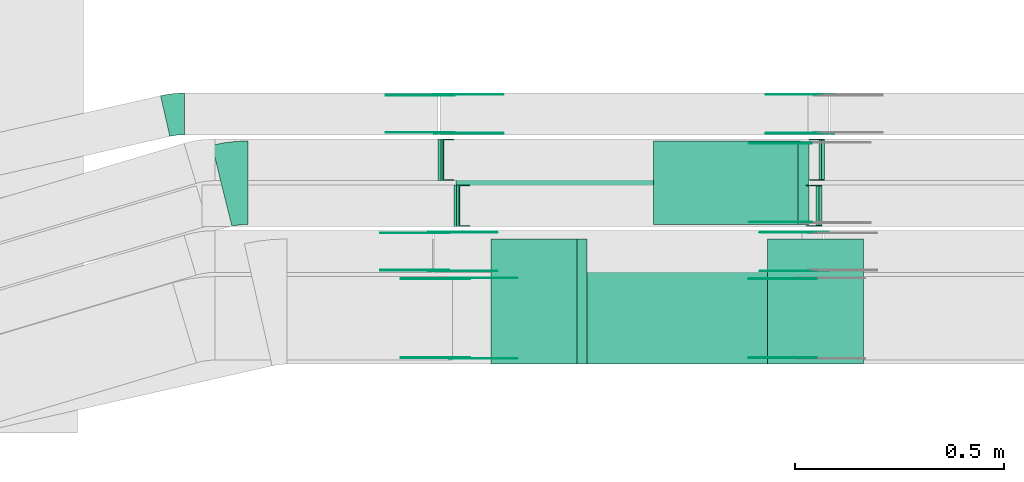
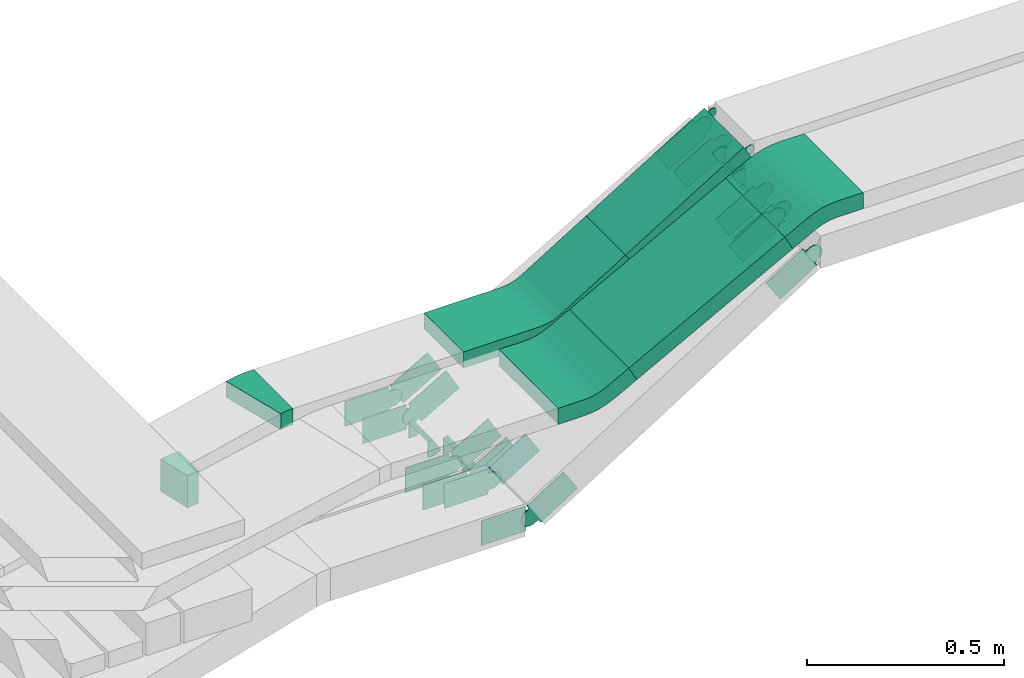
# One storey, part 25 of 31: 29 flow fittings, 2 flow segments.
"""IFC2X3 building model written with IfcOpenShell, lengths in millimetres."""

import ifcopenshell
import ifcopenshell.guid

model = None  # the IFC model being written
_history = None  # IfcOwnerHistory: only IFC2X3 demands one
_inside = {}  # id of a spatial element -> (the spatial element, [elements in it])
_under = {}  # id of a project, library or spatial element -> (it, [spatial elements below it])
_declared = {}  # id of a project -> (the project, [libraries it declares])
_typed = {}  # id of a type object -> (the type object, [elements of that type])
_made_of = {}  # id of a material, layer set ... -> (it, [elements and type objects made of it])


def new_model(schema):
    """Start an empty IFC model of exactly this schema.

    Asked for "IFC4X3", IfcOpenShell would pick the latest addendum, in which some entities
    have other attributes; the version numbers below select the first issue.
    IFC2X3 requires an IfcOwnerHistory on every rooted entity: one is made here for all.
    """
    global model, _history
    if schema == "IFC4X3":
        model = ifcopenshell.file(schema_version=(4, 3, 0, 0))
    else:
        model = ifcopenshell.file(schema=schema)
    _inside.clear()
    _under.clear()
    _declared.clear()
    _typed.clear()
    _made_of.clear()
    _history = None
    if model.schema == "IFC2X3":
        org = make("IfcOrganization", Name="unknown")
        user = make(
            "IfcPersonAndOrganization",
            ThePerson=make("IfcPerson", FamilyName="unknown"),
            TheOrganization=org,
        )
        app = make(
            "IfcApplication",
            ApplicationDeveloper=org,
            Version="unknown",
            ApplicationFullName="unknown",
            ApplicationIdentifier="unknown",
        )
        _history = make(
            "IfcOwnerHistory",
            OwningUser=user,
            OwningApplication=app,
            ChangeAction="ADDED",
            CreationDate=0,
        )
    return model


def make(cls, **values):
    """One entity of the class cls with the attributes given. An attribute that is None is left unset."""
    return model.create_entity(
        cls, **{name: value for name, value in values.items() if value is not None}
    )


def entity(cls, *values):
    """Any entity or typed value of the class cls, its attributes in the order of the schema. None: left unset."""
    e = model.create_entity(cls)
    for i, value in enumerate(values):
        if value is not None:
            e[i] = value
    return e


def rooted(cls, **values):
    """An entity with a GlobalId (a new one), such as an element, a storey or a relation."""
    return make(cls, GlobalId=ifcopenshell.guid.new(), OwnerHistory=_history, **values)


def si_unit(unit_type, name, prefix=None):
    """IfcSIUnit, for example si_unit("LENGTHUNIT", "METRE", prefix="MILLI")."""
    return make("IfcSIUnit", UnitType=unit_type, Prefix=prefix, Name=name)


def converted_unit(unit_type, name, factor, base, dimensions=None, offset=None):
    """IfcConversionBasedUnit, such as the inch: factor (a typed value) times the base unit."""
    return make(
        "IfcConversionBasedUnit"
        if offset is None
        else "IfcConversionBasedUnitWithOffset",
        ConversionOffset=offset,
        Dimensions=None
        if dimensions is None
        else entity("IfcDimensionalExponents", *dimensions),
        UnitType=unit_type,
        Name=name,
        ConversionFactor=make(
            "IfcMeasureWithUnit", ValueComponent=factor, UnitComponent=base
        ),
    )


def derived_unit(unit_type, elements):
    """IfcDerivedUnit: a product of units, each with its exponent."""
    return make(
        "IfcDerivedUnit",
        Elements=[
            make("IfcDerivedUnitElement", Unit=unit, Exponent=power)
            for unit, power in elements
        ],
        UnitType=unit_type,
    )


def assignment(units):
    """IfcUnitAssignment: the units of a project."""
    return None if units is None else make("IfcUnitAssignment", Units=units)


def point(xyz):
    """IfcCartesianPoint."""
    return None if xyz is None else make("IfcCartesianPoint", Coordinates=xyz)


def direction(xyz):
    """IfcDirection."""
    return None if xyz is None else make("IfcDirection", DirectionRatios=xyz)


def frame(location, z_axis=None, x_axis=None):
    """IfcAxis2Placement3D, a coordinate frame: its origin and axes. An axis left out is left unset."""
    return make(
        "IfcAxis2Placement3D",
        Location=point(location),
        Axis=direction(z_axis),
        RefDirection=direction(x_axis),
    )


def frame_2d(location, x_axis=None):
    """IfcAxis2Placement2D, a coordinate frame in the plane: its origin and x axis."""
    return make(
        "IfcAxis2Placement2D", Location=point(location), RefDirection=direction(x_axis)
    )


def origin():
    """The frame at (0, 0, 0) with its axes left unset."""
    return frame((0.0, 0.0, 0.0))


def origin_2d_with_axis():
    """The frame at (0, 0) in the plane with the x axis (1, 0) written out."""
    return frame_2d((0.0, 0.0), x_axis=(1.0, 0.0))


def place(relative_to, where):
    """IfcLocalPlacement: puts the frame where relative to a parent placement (None: the world)."""
    return make(
        "IfcLocalPlacement", PlacementRelTo=relative_to, RelativePlacement=where
    )


def context(
    kind, dimensions, precision=None, world=None, true_north=None, identifier=None
):
    """IfcGeometricRepresentationContext, for example the 3D "Model" context."""
    return make(
        "IfcGeometricRepresentationContext",
        ContextIdentifier=identifier,
        ContextType=kind,
        CoordinateSpaceDimension=dimensions,
        Precision=precision,
        WorldCoordinateSystem=world,
        TrueNorth=true_north,
    )


def subcontext(parent, identifier, kind, view, scale=None):
    """IfcGeometricRepresentationSubContext, for example "Body" below "Model"."""
    return make(
        "IfcGeometricRepresentationSubContext",
        ContextIdentifier=identifier,
        ContextType=kind,
        ParentContext=parent,
        TargetScale=scale,
        TargetView=view,
    )


def project(units=None, contexts=None):
    """IfcProject with its units and contexts."""
    return rooted(
        "IfcProject",
        Name="project",
        RepresentationContexts=contexts,
        UnitsInContext=assignment(units),
    )


def spatial(cls, under=None, at=None, **own):
    """A site, building, storey or space (cls), placed at a placement, below another one or the project."""
    s = rooted(cls, ObjectPlacement=at, **own)
    if under is not None:
        _under.setdefault(under.id(), (under, []))[1].append(s)
    return s


def polyline(points):
    """IfcPolyline through the points."""
    return make("IfcPolyline", Points=[point(p) for p in points])


def circle_curve(where, radius):
    """IfcCircle in the frame where."""
    return make("IfcCircle", Position=where, Radius=radius)


def parameter(value):
    """IfcParameterValue: where a trimmed curve begins or ends, as a parameter of its basis curve."""
    return model.create_entity("IfcParameterValue", value)


def trimmed(basis, trim1, trim2, sense, master):
    """IfcTrimmedCurve: the piece of a basis curve between two trims."""
    return make(
        "IfcTrimmedCurve",
        BasisCurve=basis,
        Trim1=trim1,
        Trim2=trim2,
        SenseAgreement=sense,
        MasterRepresentation=master,
    )


def segment(curve, same_sense, transition):
    """IfcCompositeCurveSegment."""
    return make(
        "IfcCompositeCurveSegment",
        Transition=transition,
        SameSense=same_sense,
        ParentCurve=curve,
    )


def composite_curve(segments, self_intersect=None):
    """IfcCompositeCurve: segments joined end to end."""
    return make("IfcCompositeCurve", Segments=segments, SelfIntersect=self_intersect)


def profile(cls, at=None, kind="AREA", **sizes):
    """A parametric profile (cls). Its sizes go by their IFC names, for example OverallWidth=200.0."""
    return make(cls, ProfileType=kind, Position=at, **sizes)


def rectangle(**sizes):
    """IfcRectangleProfileDef."""
    return profile("IfcRectangleProfileDef", **sizes)


def outline(outer, holes=None, kind="AREA"):
    """IfcArbitraryClosedProfileDef: a profile drawn as a closed curve; with holes, ...WithVoids."""
    if holes is None:
        return make("IfcArbitraryClosedProfileDef", ProfileType=kind, OuterCurve=outer)
    return make(
        "IfcArbitraryProfileDefWithVoids",
        ProfileType=kind,
        OuterCurve=outer,
        InnerCurves=holes,
    )


def extrude(swept, where, along, depth):
    """IfcExtrudedAreaSolid: the profile swept, set in the frame where, extruded along a direction by depth."""
    return make(
        "IfcExtrudedAreaSolid",
        SweptArea=swept,
        Position=where,
        ExtrudedDirection=direction(along),
        Depth=depth,
    )


def faces_of(points, faces, orient=None, outer=None):
    """IfcFace entities. A face is a list of loops; a loop is a list of indices into points, from 0.

    orient and outer hold one flag for each loop. By default every Orientation is true, the
    first loop of a face is its IfcFaceOuterBound and the others are IfcFaceBound.
    """
    made = []
    for i, loops in enumerate(faces):
        bounds = []
        for j, loop in enumerate(loops):
            is_outer = j == 0 if outer is None else outer[i][j]
            bounds.append(
                make(
                    "IfcFaceOuterBound" if is_outer else "IfcFaceBound",
                    Bound=make("IfcPolyLoop", Polygon=[points[k] for k in loop]),
                    Orientation=True if orient is None else orient[i][j],
                )
            )
        made.append(make("IfcFace", Bounds=bounds))
    return made


def faceted_brep(points, faces, orient=None, outer=None, voids=None):
    """IfcFacetedBrep: a solid bounded by flat faces; with voids (closed shells), ...WithVoids."""
    shared = [point(p) for p in points]
    hull = make("IfcClosedShell", CfsFaces=faces_of(shared, faces, orient, outer))
    if voids is None:
        return make("IfcFacetedBrep", Outer=hull)
    return make(
        "IfcFacetedBrepWithVoids",
        Outer=hull,
        Voids=[
            make(cls, CfsFaces=faces_of(shared, fs, o, b)) for cls, fs, o, b in voids
        ],
    )


def shape(context_of_items, identifier, shape_type, items):
    """IfcShapeRepresentation: the items that make up one representation, for example the "Body"."""
    return make(
        "IfcShapeRepresentation",
        ContextOfItems=context_of_items,
        RepresentationIdentifier=identifier,
        RepresentationType=shape_type,
        Items=items,
    )


def source(mapping_origin, context_of_items, identifier, shape_type, items):
    """IfcRepresentationMap: a shape defined once, which mapped items show again and again."""
    return make(
        "IfcRepresentationMap",
        MappingOrigin=mapping_origin,
        MappedRepresentation=shape(context_of_items, identifier, shape_type, items),
    )


def transform(
    local_origin,
    x_axis=None,
    y_axis=None,
    z_axis=None,
    scale=None,
    scale2=None,
    scale3=None,
    uniform=True,
):
    """IfcCartesianTransformationOperator3D, or its non-uniform kind. x_axis, y_axis, z_axis: its Axis1, 2, 3."""
    if uniform:
        return make(
            "IfcCartesianTransformationOperator3D",
            Axis1=direction(x_axis),
            Axis2=direction(y_axis),
            LocalOrigin=point(local_origin),
            Scale=scale,
            Axis3=direction(z_axis),
        )
    return make(
        "IfcCartesianTransformationOperator3DnonUniform",
        Axis1=direction(x_axis),
        Axis2=direction(y_axis),
        LocalOrigin=point(local_origin),
        Scale=scale,
        Axis3=direction(z_axis),
        Scale2=scale2,
        Scale3=scale3,
    )


def mapped(mapping_source, mapping_target):
    """IfcMappedItem: shows the shape of a source again, moved by a transform."""
    return make(
        "IfcMappedItem", MappingSource=mapping_source, MappingTarget=mapping_target
    )


def material(Name=None, Category=None):
    """IfcMaterial."""
    return make("IfcMaterial", Name=Name, Category=Category)


def made_of(thing, what):
    """Note that an element or type object is made of a material, layer set ...; save() writes the relation."""
    if what is not None:
        _made_of.setdefault(what.id(), (what, []))[1].append(thing)
    return thing


def type_object(cls, material=None, **own):
    """A type object (cls), such as IfcWallType, which elements share."""
    return made_of(rooted(cls, **own), material)


def type_shapes(of_type, sources):
    """Give a type object the sources (RepresentationMaps) that its elements show as mapped items."""
    of_type.RepresentationMaps = sources


def element(
    cls,
    number,
    at=None,
    inside=None,
    cuts=None,
    type_object=None,
    material=None,
    context=None,
    identifier="Body",
    shape_type=None,
    held_by="IfcProductDefinitionShape",
    body=None,
    shapes=None,
    **own,
):
    """One element of the class cls, such as IfcWall. Its Tag is "e" and its number.

    at: its placement. inside: the storey or other place that contains it. cuts: it is an
    opening in that element (IfcRelVoidsElement). A single representation is given by context,
    identifier, shape_type and body (its items); several are given by shapes. held_by: the class
    of the entity that holds the representations. save() writes the other relations.
    """
    e = rooted(cls, Tag="e%d" % number, ObjectPlacement=at, **own)
    if body is not None:
        shapes = [shape(context, identifier, shape_type, body)]
    if shapes is not None:
        e.Representation = make(held_by, Representations=shapes)
    if inside is not None:
        _inside.setdefault(inside.id(), (inside, []))[1].append(e)
    if cuts is not None:
        rooted(
            "IfcRelVoidsElement", RelatingBuildingElement=cuts, RelatedOpeningElement=e
        )
    if type_object is not None:
        _typed.setdefault(type_object.id(), (type_object, []))[1].append(e)
    return made_of(e, material)


def aggregate(whole, parts):
    """IfcRelAggregates: a whole, such as a stair, and the parts it consists of."""
    return rooted("IfcRelAggregates", RelatingObject=whole, RelatedObjects=parts)


def save(model, path):
    """Write the relations noted so far, then the file.

    IfcRelAggregates (storeys below a building ...), IfcRelContainedInSpatialStructure (elements
    in a storey), IfcRelDefinesByType, IfcRelAssociatesMaterial and IfcRelDeclares: one each for
    every whole, place, type object, material and project.
    """
    for whole, parts in _under.values():
        aggregate(whole, parts)
    for where, things in _inside.values():
        rooted(
            "IfcRelContainedInSpatialStructure",
            RelatedElements=things,
            RelatingStructure=where,
        )
    for kind, things in _typed.values():
        rooted("IfcRelDefinesByType", RelatedObjects=things, RelatingType=kind)
    for what, things in _made_of.values():
        rooted("IfcRelAssociatesMaterial", RelatedObjects=things, RelatingMaterial=what)
    for by, libraries in _declared.values():
        rooted("IfcRelDeclares", RelatingContext=by, RelatedDefinitions=libraries)
    model.write(path)


model = new_model("IFC2X3")

# Units and contexts
model_context = context("Model", 3, precision=0.01, world=origin(), true_north=direction((6.12303176911189e-17, 1.0)))
body_context = subcontext(model_context, "Body", "Model", "MODEL_VIEW")
ifc_project = project(units=[si_unit("LENGTHUNIT", "METRE", prefix="MILLI"), si_unit("AREAUNIT", "SQUARE_METRE"), si_unit("VOLUMEUNIT", "CUBIC_METRE"), converted_unit("PLANEANGLEUNIT", "DEGREE", entity("IfcRatioMeasure", 0.0174532925199433), si_unit("PLANEANGLEUNIT", "RADIAN"), dimensions=[0, 0, 0, 0, 0, 0, 0]), si_unit("MASSUNIT", "GRAM", prefix="KILO"), derived_unit("MASSDENSITYUNIT", [(si_unit("MASSUNIT", "GRAM", prefix="KILO"), 1), (si_unit("LENGTHUNIT", "METRE"), -3)]), derived_unit("MOMENTOFINERTIAUNIT", [(si_unit("LENGTHUNIT", "METRE"), 4)]), si_unit("TIMEUNIT", "SECOND"), si_unit("FREQUENCYUNIT", "HERTZ"), si_unit("THERMODYNAMICTEMPERATUREUNIT", "DEGREE_CELSIUS"), derived_unit("THERMALTRANSMITTANCEUNIT", [(si_unit("MASSUNIT", "GRAM", prefix="KILO"), 1), (si_unit("THERMODYNAMICTEMPERATUREUNIT", "KELVIN"), -1), (si_unit("TIMEUNIT", "SECOND"), -3)]), derived_unit("VOLUMETRICFLOWRATEUNIT", [(si_unit("LENGTHUNIT", "METRE"), 3), (si_unit("TIMEUNIT", "SECOND"), -1)]), derived_unit("MASSFLOWRATEUNIT", [(si_unit("MASSUNIT", "GRAM", prefix="KILO"), 1), (si_unit("TIMEUNIT", "SECOND"), -1)]), derived_unit("ROTATIONALFREQUENCYUNIT", [(si_unit("TIMEUNIT", "SECOND"), -1)]), si_unit("ELECTRICCURRENTUNIT", "AMPERE"), si_unit("ELECTRICVOLTAGEUNIT", "VOLT"), si_unit("POWERUNIT", "WATT"), si_unit("FORCEUNIT", "NEWTON", prefix="KILO"), si_unit("ILLUMINANCEUNIT", "LUX"), si_unit("LUMINOUSFLUXUNIT", "LUMEN"), si_unit("LUMINOUSINTENSITYUNIT", "CANDELA"), derived_unit("USERDEFINED", [(si_unit("MASSUNIT", "GRAM", prefix="KILO"), -1), (si_unit("LENGTHUNIT", "METRE"), -2), (si_unit("TIMEUNIT", "SECOND"), 3), (si_unit("LUMINOUSFLUXUNIT", "LUMEN"), 1)]), derived_unit("LINEARVELOCITYUNIT", [(si_unit("LENGTHUNIT", "METRE"), 1), (si_unit("TIMEUNIT", "SECOND"), -1)]), si_unit("PRESSUREUNIT", "PASCAL"), derived_unit("USERDEFINED", [(si_unit("LENGTHUNIT", "METRE"), -2), (si_unit("MASSUNIT", "GRAM", prefix="KILO"), 1), (si_unit("TIMEUNIT", "SECOND"), -2)]), derived_unit("LINEARFORCEUNIT", [(si_unit("MASSUNIT", "GRAM", prefix="KILO"), 1), (si_unit("LENGTHUNIT", "METRE"), 1), (si_unit("TIMEUNIT", "SECOND"), -2), (si_unit("LENGTHUNIT", "METRE"), -1)]), derived_unit("PLANARFORCEUNIT", [(si_unit("MASSUNIT", "GRAM", prefix="KILO"), 1), (si_unit("LENGTHUNIT", "METRE"), 1), (si_unit("TIMEUNIT", "SECOND"), -2), (si_unit("LENGTHUNIT", "METRE"), -2)])], contexts=[model_context])

# Site, building, storey
site_placement = place(None, frame((0.0, -0.00077364408347762, 0.0)))
site = spatial("IfcSite", under=ifc_project, at=site_placement, CompositionType="ELEMENT")
building_placement = place(site_placement, origin())
building = spatial("IfcBuilding", under=site, at=building_placement, CompositionType="ELEMENT")
storey_placement = place(building_placement, frame((0.0, 0.0, 15900.0)))
storey = spatial("IfcBuildingStorey", under=building, at=storey_placement, CompositionType="ELEMENT", Elevation=15900.0)

# Flow segments
cable_carrier_segment_type = type_object("IfcCableCarrierSegmentType", PredefinedType="CABLETRAYSEGMENT")
flow_segment_1_placement = place(storey_placement, frame((62147.1485246267, 8800.14842319196, 2961.37570355346)))
element("IfcFlowSegment", 1, at=flow_segment_1_placement, inside=storey, type_object=cable_carrier_segment_type, context=body_context, shape_type="SweptSolid", body=[
    extrude(rectangle(XDim=50.000000000001, YDim=200.0, at=frame_2d((-9.2192919964873e-13, 0.0), x_axis=(1.0, 0.0))), frame((13.0909688854445, 100.0, 21.2985101272518), z_axis=(0.851940405089881, 0.0, 0.523638755417596), x_axis=(-0.523638755417596, 0.0, 0.851940405089881)), (0.0, 0.0, 1.0), 405.830197083303),
])
flow_segment_2_placement = place(storey_placement, frame((61963.2736201041, 8465.14842319196, 2877.86247306309)))
element("IfcFlowSegment", 2, at=flow_segment_2_placement, inside=storey, type_object=cable_carrier_segment_type, context=body_context, shape_type="SweptSolid", body=[
    extrude(rectangle(XDim=49.9999999999993, YDim=299.999999999999, at=origin_2d_with_axis()), frame((11.830067947996, 150.0, 22.0238391827057), z_axis=(0.880953567308328, 0.0, 0.473202717919848), x_axis=(-0.473202717919848, 0.0, 0.880953567308328)), (0.0, 0.0, 1.0), 518.229008882918),
])

# Flow fittings
ifc_material_1 = material(Name="G")
cable_carrier_fitting_type_1 = type_object("IfcCableCarrierFittingType", PredefinedType="NOTDEFINED", material=ifc_material_1)
shared_shape_1 = source(origin(), body_context, "Body", "SweptSolid", [
    extrude(outline(composite_curve([segment(trimmed(circle_curve(frame_2d((-44.5901162790698, 0.0), x_axis=(1.0, 0.0)), 12.5), [parameter(90.0000000000007)], [parameter(270.0)], True, "PARAMETER"), True, "CONTINUOUS"), segment(polyline([(-44.5901162790697, -12.5), (-33.0901162790698, -12.5)]), True, "CONTINUOUS"), segment(polyline([(-33.0901162790698, -12.5), (-31.2296511627907, -14.5)]), True, "CONTINUOUS"), segment(polyline([(-31.2296511627907, -14.5), (108.90988372093, -14.5)]), True, "CONTINUOUS"), segment(polyline([(108.90988372093, -14.5), (108.90988372093, 14.5)]), True, "CONTINUOUS"), segment(polyline([(108.90988372093, 14.5), (-31.2296511627907, 14.5)]), True, "CONTINUOUS"), segment(polyline([(-31.2296511627907, 14.5), (-33.0901162790698, 12.5)]), True, "CONTINUOUS"), segment(polyline([(-33.0901162790698, 12.5), (-44.5901162790699, 12.5)]), True, "CONTINUOUS")], self_intersect=False)), frame((44.5901162790698, 0.0, 0.0), z_axis=(0.0, 0.0, -1.0), x_axis=(1.0, 0.0, 0.0)), (0.0, 0.0, -1.0), 2.0),
])
type_shapes(cable_carrier_fitting_type_1, [shared_shape_1])
flow_fitting_1_placement = place(storey_placement, frame((62513.8203095191, 8806.68842318183, 3200.0), z_axis=(0.0, -1.0, 0.0), x_axis=(-0.851940405089901, 0.0, -0.523638755417564)))
element("IfcFlowFitting", 3, at=flow_fitting_1_placement, inside=storey, type_object=cable_carrier_fitting_type_1, material=ifc_material_1, context=body_context, shape_type="MappedRepresentation", body=[
    mapped(shared_shape_1, transform((0.0, 0.0, 0.0), scale=1.0)),
])
cable_carrier_fitting_type_2 = type_object("IfcCableCarrierFittingType", PredefinedType="NOTDEFINED", material=ifc_material_1)
shared_shape_2 = source(origin(), body_context, "Body", "SweptSolid", [
    extrude(outline(composite_curve([segment(trimmed(circle_curve(frame_2d((-44.5901162790697, 0.0), x_axis=(1.0, 0.0)), 12.5), [parameter(90.0000000000007)], [parameter(270.0)], True, "PARAMETER"), True, "CONTINUOUS"), segment(polyline([(-44.5901162790697, -12.5), (-33.0901162790697, -12.5)]), True, "CONTINUOUS"), segment(polyline([(-33.0901162790697, -12.5), (-31.2296511627907, -14.5)]), True, "CONTINUOUS"), segment(polyline([(-31.2296511627907, -14.5), (108.90988372093, -14.5)]), True, "CONTINUOUS"), segment(polyline([(108.90988372093, -14.5), (108.90988372093, 14.5)]), True, "CONTINUOUS"), segment(polyline([(108.90988372093, 14.5), (-31.2296511627907, 14.5)]), True, "CONTINUOUS"), segment(polyline([(-31.2296511627907, 14.5), (-33.0901162790698, 12.5)]), True, "CONTINUOUS"), segment(polyline([(-33.0901162790698, 12.5), (-44.5901162790699, 12.5)]), True, "CONTINUOUS")], self_intersect=False)), frame((44.5901162790697, 0.0, 0.0)), (0.0, 0.0, 1.0), 2.0),
])
type_shapes(cable_carrier_fitting_type_2, [shared_shape_2])
flow_fitting_2_placement = place(storey_placement, frame((62513.8203095191, 8993.60842320215, 3200.0), z_axis=(0.0, 1.0, 0.0), x_axis=(-0.851940405089901, 0.0, -0.523638755417564)))
element("IfcFlowFitting", 4, at=flow_fitting_2_placement, inside=storey, type_object=cable_carrier_fitting_type_2, material=ifc_material_1, context=body_context, shape_type="MappedRepresentation", body=[
    mapped(shared_shape_2, transform((0.0, 0.0, 0.0), scale=1.0)),
])
ifc_material_2 = material()
cable_carrier_fitting_type_3 = type_object("IfcCableCarrierFittingType", Name="470_DKC_S5_Variable Angle Elbow 0-45:-", PredefinedType="NOTDEFINED", material=ifc_material_2)
shared_shape_3 = source(origin(), body_context, "Body", "SweptSolid", [
    extrude(outline(composite_curve([segment(polyline([(-31.1151746699764, -103.743995335232), (-30.115174669975, -103.743995335232)]), True, "CONTINUOUS"), segment(trimmed(circle_curve(frame_2d((-30.1151746699696, 246.256004664767), x_axis=(0.0, -1.0)), 350.0), [parameter(0.0)], [parameter(13.9444078794154)], True, "PARAMETER"), True, "CONTINUOUS"), segment(polyline([(54.227943407356, -93.4294946327361), (55.1984734053488, -93.1885142953723)]), True, "CONTINUOUS"), segment(polyline([(55.1984734053488, -93.1885142953723), (7.00240593259137, 100.917485303201)]), True, "CONTINUOUS"), segment(polyline([(7.00240593259137, 100.917485303201), (6.03187593459847, 100.676504965837)]), True, "CONTINUOUS"), segment(trimmed(circle_curve(frame_2d((-30.1151746699696, 246.256004664767), x_axis=(0.0, -1.0)), 150.0), [parameter(0.0)], [parameter(13.9444078794154)], True, "PARAMETER"), False, "CONTINUOUS"), segment(polyline([(-30.1151746699716, 96.2560046647674), (-31.115174669973, 96.2560046647674)]), True, "CONTINUOUS"), segment(polyline([(-31.115174669973, 96.2560046647674), (-31.1151746699764, -103.743995335232)]), True, "CONTINUOUS")], self_intersect=False)), frame((-0.457861214940671, 3.74399533522495, -25.0)), (0.0, 0.0, 1.0), 50.0000000000004),
])
type_shapes(cable_carrier_fitting_type_3, [shared_shape_3])
flow_fitting_3_placement = place(storey_placement, frame((61142.6320713382, 8900.14842319199, 2845.0), z_axis=(0.0, 0.0, 1.0), x_axis=(-1.0, 0.0, 0.0)))
element("IfcFlowFitting", 5, at=flow_fitting_3_placement, inside=storey, type_object=cable_carrier_fitting_type_3, material=ifc_material_2, Name="470_DKC_S5_Variable Angle Elbow 0-45:-", ObjectType="470_DKC_S5_Variable Angle Elbow 0-45:-", context=body_context, shape_type="MappedRepresentation", body=[
    mapped(shared_shape_3, transform((0.0, 0.0, 0.0), scale=1.0)),
])
cable_carrier_fitting_type_4 = type_object("IfcCableCarrierFittingType", PredefinedType="NOTDEFINED", material=ifc_material_1)
shared_shape_4 = source(origin(), body_context, "Body", "SweptSolid", [
    extrude(outline(composite_curve([segment(trimmed(circle_curve(frame_2d((-41.4651162790697, 0.0), x_axis=(1.0, 0.0)), 25.0), [parameter(90.0000000000007)], [parameter(270.0)], True, "PARAMETER"), True, "CONTINUOUS"), segment(polyline([(-41.4651162790697, -25.0), (-29.9651162790697, -25.0)]), True, "CONTINUOUS"), segment(polyline([(-29.9651162790697, -25.0), (-28.1046511627907, -38.5)]), True, "CONTINUOUS"), segment(polyline([(-28.1046511627907, -38.5), (99.5348837209303, -38.5)]), True, "CONTINUOUS"), segment(polyline([(99.5348837209303, -38.5), (99.5348837209303, 38.5)]), True, "CONTINUOUS"), segment(polyline([(99.5348837209303, 38.5), (-28.1046511627907, 38.5)]), True, "CONTINUOUS"), segment(polyline([(-28.1046511627907, 38.5), (-29.9651162790697, 25.0)]), True, "CONTINUOUS"), segment(polyline([(-29.9651162790697, 25.0), (-41.46511627907, 25.0)]), True, "CONTINUOUS")], self_intersect=False)), frame((41.4651162790697, 0.0, 0.0), z_axis=(0.0, 0.0, -1.0), x_axis=(1.0, 0.0, 0.0)), (0.0, 0.0, -1.0), 2.0),
])
type_shapes(cable_carrier_fitting_type_4, [shared_shape_4])
for number, where, z_axis, x_axis in (
    (6, (62541.5522892822, 8689.50586238482, 3075.43501652418), (0.0, -1.0, 0.0), (-0.865893399879645, 0.0, -0.50022856780163)),
    (7, (61632.0266400906, 8689.50586238485, 2550.0), (0.0, -1.0, 0.0), (0.865893399879645, 0.0, 0.50022856780163)),
    (8, (62555.3882264997, 9019.5058623849, 3075.43501652419), (0.0, -1.0, 0.0), (-0.865893399879645, 0.0, -0.50022856780163)),
    (9, (61645.8625773081, 9019.50586238495, 2550.0), (0.0, -1.0, 0.0), (0.865893399879645, 0.0, 0.50022856780163)),
    (10, (61682.0266400907, 8479.50586238485, 2550.0), (0.0, -1.0, 0.0), (0.845240241928741, 0.0, 0.534386501910596)),
):
    element("IfcFlowFitting", number, at=place(storey_placement, frame(where, z_axis=z_axis, x_axis=x_axis)), inside=storey, type_object=cable_carrier_fitting_type_4, material=ifc_material_1, context=body_context, shape_type="MappedRepresentation", body=[
        mapped(shared_shape_4, transform((0.0, 0.0, 0.0), scale=1.0)),
    ])
cable_carrier_fitting_type_5 = type_object("IfcCableCarrierFittingType", PredefinedType="NOTDEFINED", material=ifc_material_1)
shared_shape_5 = source(origin(), body_context, "Body", "SweptSolid", [
    extrude(outline(composite_curve([segment(trimmed(circle_curve(frame_2d((-41.4651162790697, 0.0), x_axis=(1.0, 0.0)), 25.0), [parameter(90.0000000000007)], [parameter(270.0)], True, "PARAMETER"), True, "CONTINUOUS"), segment(polyline([(-41.4651162790697, -25.0), (-29.9651162790697, -25.0)]), True, "CONTINUOUS"), segment(polyline([(-29.9651162790697, -25.0), (-28.1046511627907, -38.5)]), True, "CONTINUOUS"), segment(polyline([(-28.1046511627907, -38.5), (99.5348837209303, -38.5)]), True, "CONTINUOUS"), segment(polyline([(99.5348837209303, -38.5), (99.5348837209303, 38.5)]), True, "CONTINUOUS"), segment(polyline([(99.5348837209303, 38.5), (-28.1046511627907, 38.5)]), True, "CONTINUOUS"), segment(polyline([(-28.1046511627907, 38.5), (-29.9651162790697, 25.0)]), True, "CONTINUOUS"), segment(polyline([(-29.9651162790697, 25.0), (-41.46511627907, 25.0)]), True, "CONTINUOUS")], self_intersect=False)), frame((41.4651162790697, 0.0, 0.0)), (0.0, 0.0, 1.0), 2.0),
])
type_shapes(cable_carrier_fitting_type_5, [shared_shape_5])
for number, where, z_axis, x_axis in (
    (11, (62541.5522892822, 8780.42586240514, 3075.43501652419), (0.0, 1.0, 0.0), (-0.865893399879645, 0.0, -0.50022856780163)),
    (12, (61632.0266400906, 8780.42586240517, 2550.0), (0.0, 1.0, 0.0), (0.865893399879645, 0.0, 0.50022856780163)),
    (13, (62555.3882264997, 9110.42586240522, 3075.43501652419), (0.0, 1.0, 0.0), (-0.865893399879645, 0.0, -0.50022856780163)),
    (14, (61645.8625773081, 9110.42586240527, 2550.0), (0.0, 1.0, 0.0), (0.865893399879645, 0.0, 0.50022856780163)),
    (15, (61682.0266400907, 8670.42586240517, 2550.0), (0.0, 1.0, 0.0), (0.845240241928741, 0.0, 0.534386501910596)),
):
    element("IfcFlowFitting", number, at=place(storey_placement, frame(where, z_axis=z_axis, x_axis=x_axis)), inside=storey, type_object=cable_carrier_fitting_type_5, material=ifc_material_1, context=body_context, shape_type="MappedRepresentation", body=[
        mapped(shared_shape_5, transform((0.0, 0.0, 0.0), scale=1.0)),
    ])
cable_carrier_fitting_type_6 = type_object("IfcCableCarrierFittingType", PredefinedType="NOTDEFINED", material=ifc_material_1)
shared_shape_6 = source(origin(), body_context, "Body", "SweptSolid", [
    extrude(outline(composite_curve([segment(trimmed(circle_curve(frame_2d((-41.4651162790697, 0.0), x_axis=(1.0, 0.0)), 25.0), [parameter(90.0000000000007)], [parameter(270.0)], True, "PARAMETER"), True, "CONTINUOUS"), segment(polyline([(-41.4651162790697, -25.0), (-29.9651162790697, -25.0)]), True, "CONTINUOUS"), segment(polyline([(-29.9651162790697, -25.0), (-28.1046511627907, -38.5)]), True, "CONTINUOUS"), segment(polyline([(-28.1046511627907, -38.5), (99.5348837209303, -38.5)]), True, "CONTINUOUS"), segment(polyline([(99.5348837209303, -38.5), (99.5348837209303, 38.5)]), True, "CONTINUOUS"), segment(polyline([(99.5348837209303, 38.5), (-28.1046511627907, 38.5)]), True, "CONTINUOUS"), segment(polyline([(-28.1046511627907, 38.5), (-29.9651162790697, 25.0)]), True, "CONTINUOUS"), segment(polyline([(-29.9651162790697, 25.0), (-41.46511627907, 25.0)]), True, "CONTINUOUS")], self_intersect=False)), frame((41.4651162790697, 0.0, 0.0), z_axis=(0.0, 0.0, -1.0), x_axis=(1.0, 0.0, 0.0)), (0.0, 0.0, -1.0), 2.0),
])
type_shapes(cable_carrier_fitting_type_6, [shared_shape_6])
for number, where, z_axis, x_axis in (
    (16, (61632.0266400907, 8778.42586240517, 2550.0), (0.0, 1.0, 0.0), (-1.0, 0.0, 0.0)),
    (17, (61645.8625773081, 9108.42586240527, 2550.0), (0.0, 1.0, 0.0), (-1.0, 0.0, 0.0)),
    (18, (61682.0266400907, 8668.42586240517, 2550.0), (0.0, 1.0, 0.0), (-1.0, 0.0, 0.0)),
    (19, (62513.1082989591, 8481.50586238475, 3075.43501652421), (0.0, -1.0, 0.0), (-0.845240241928726, 0.0, -0.53438650191062)),
):
    element("IfcFlowFitting", number, at=place(storey_placement, frame(where, z_axis=z_axis, x_axis=x_axis)), inside=storey, type_object=cable_carrier_fitting_type_6, material=ifc_material_1, context=body_context, shape_type="MappedRepresentation", body=[
        mapped(shared_shape_6, transform((0.0, 0.0, 0.0), scale=1.0)),
    ])
cable_carrier_fitting_type_7 = type_object("IfcCableCarrierFittingType", PredefinedType="NOTDEFINED", material=ifc_material_1)
shared_shape_7 = source(origin(), body_context, "Body", "SweptSolid", [
    extrude(outline(composite_curve([segment(trimmed(circle_curve(frame_2d((-41.4651162790697, 0.0), x_axis=(1.0, 0.0)), 25.0), [parameter(90.0000000000007)], [parameter(270.0)], True, "PARAMETER"), True, "CONTINUOUS"), segment(polyline([(-41.4651162790697, -25.0), (-29.9651162790697, -25.0)]), True, "CONTINUOUS"), segment(polyline([(-29.9651162790697, -25.0), (-28.1046511627907, -38.5)]), True, "CONTINUOUS"), segment(polyline([(-28.1046511627907, -38.5), (99.5348837209303, -38.5)]), True, "CONTINUOUS"), segment(polyline([(99.5348837209303, -38.5), (99.5348837209303, 38.5)]), True, "CONTINUOUS"), segment(polyline([(99.5348837209303, 38.5), (-28.1046511627907, 38.5)]), True, "CONTINUOUS"), segment(polyline([(-28.1046511627907, 38.5), (-29.9651162790697, 25.0)]), True, "CONTINUOUS"), segment(polyline([(-29.9651162790697, 25.0), (-41.46511627907, 25.0)]), True, "CONTINUOUS")], self_intersect=False)), frame((41.4651162790697, 0.0, 0.0)), (0.0, 0.0, 1.0), 2.0),
])
type_shapes(cable_carrier_fitting_type_7, [shared_shape_7])
for number, where, z_axis, x_axis in (
    (20, (61632.0266400907, 8691.50586238486, 2550.0), (0.0, -1.0, 0.0), (-1.0, 0.0, 0.0)),
    (21, (61645.8625773081, 9021.50586238495, 2550.0), (0.0, -1.0, 0.0), (-1.0, 0.0, 0.0)),
    (22, (61682.0266400907, 8481.50586238486, 2550.0), (0.0, -1.0, 0.0), (-1.0, 0.0, 0.0)),
    (23, (62513.1082989591, 8668.42586240507, 3075.4350165242), (0.0, 1.0, 0.0), (-0.845240241928726, 0.0, -0.53438650191062)),
):
    element("IfcFlowFitting", number, at=place(storey_placement, frame(where, z_axis=z_axis, x_axis=x_axis)), inside=storey, type_object=cable_carrier_fitting_type_7, material=ifc_material_1, context=body_context, shape_type="MappedRepresentation", body=[
        mapped(shared_shape_7, transform((0.0, 0.0, 0.0), scale=1.0)),
    ])
cable_carrier_fitting_type_8 = type_object("IfcCableCarrierFittingType", Name="470_DKC_S5_Variable Angle Elbow 0-45:-", PredefinedType="NOTDEFINED", material=ifc_material_2)
shared_shape_8 = source(origin(), body_context, "Body", "SweptSolid", [
    extrude(outline(composite_curve([segment(polyline([(-23.1605515764478, -52.5431907046031), (-22.1605515764465, -52.5431907046031)]), True, "CONTINUOUS"), segment(trimmed(circle_curve(frame_2d((-22.160551576449, 197.456809295397), x_axis=(0.0, -1.0)), 250.0), [parameter(0.0)], [parameter(12.8070045345923)], True, "PARAMETER"), True, "CONTINUOUS"), segment(polyline([(33.2563759507781, -46.3237562619134), (34.2314982130073, -46.1020885518044)]), True, "CONTINUOUS"), segment(polyline([(34.2314982130073, -46.1020885518044), (12.0647272021165, 51.4101376711195)]), True, "CONTINUOUS"), segment(polyline([(12.0647272021165, 51.4101376711195), (11.0896049398872, 51.1884699610106)]), True, "CONTINUOUS"), segment(trimmed(circle_curve(frame_2d((-22.160551576449, 197.456809295397), x_axis=(0.0, -1.0)), 150.0), [parameter(0.0)], [parameter(12.8070045345923)], True, "PARAMETER"), False, "CONTINUOUS"), segment(polyline([(-22.1605515764473, 47.4568092953968), (-23.1605515764486, 47.4568092953968)]), True, "CONTINUOUS"), segment(polyline([(-23.1605515764486, 47.4568092953968), (-23.1605515764478, -52.5431907046031)]), True, "CONTINUOUS")], self_intersect=False)), frame((-0.28542195621042, 2.54319070459483, -50.0)), (0.0, 0.0, 1.0), 100.0),
])
type_shapes(cable_carrier_fitting_type_8, [shared_shape_8])
flow_fitting_4_placement = place(storey_placement, frame((60998.988046221, 9064.9658623951, 2550.0), z_axis=(0.0, 0.0, 1.0), x_axis=(-1.0, 0.0, 0.0)))
element("IfcFlowFitting", 24, at=flow_fitting_4_placement, inside=storey, type_object=cable_carrier_fitting_type_8, material=ifc_material_2, Name="470_DKC_S5_Variable Angle Elbow 0-45:-", ObjectType="470_DKC_S5_Variable Angle Elbow 0-45:-", context=body_context, shape_type="MappedRepresentation", body=[
    mapped(shared_shape_8, transform((0.0, 0.0, 0.0), scale=1.0)),
])
cable_carrier_fitting_type_9 = type_object("IfcCableCarrierFittingType", PredefinedType="NOTDEFINED", material=ifc_material_2)
shared_shape_9 = source(origin(), body_context, "Body", "Brep", [
    faceted_brep([(-14.1375703553499, 25.0, 50.0), (-14.1375703553499, 25.0, -50.0), (-14.1375703553501, -25.0, -50.0), (-14.1375703553501, -25.0, -47.4600000101565), (-14.1375703553499, 22.46000001016, -47.4600000101565), (-14.1375703553499, 22.46000001016, 47.4600000101635), (-14.1375703553501, -25.0, 47.4600000101635), (-14.1375703553501, -25.0, 50.0), (-1.04660146991215, 28.7014898727511, 50.0), (25.135336300963, -13.8955303817458, 50.0), (25.135336300963, -13.8955303817458, 47.4600000101635), (0.28344096352814, 26.5375612524784, 47.4600000101635), (0.283440963528136, 26.5375612524784, -47.4600000101565), (25.135336300963, -13.8955303817458, -47.4600000101565), (25.135336300963, -13.8955303817458, -50.0), (-1.04660146991215, 28.7014898727511, -50.0), (-7.0687851776746, 25.0, 50.0), (-7.06878517767473, 25.0, -50.0), (7.06878517767563, -25.0, -50.0), (7.06878517767563, -25.0, -47.4600000101565), (-6.35059660649569, 22.46000001016, -47.4600000101565), (-6.35059660649569, 22.46000001016, 47.4600000101635), (7.06878517767563, -25.0, 47.4600000101635), (7.06878517767563, -25.0, 50.0)], [[[0, 1, 2, 3, 4, 5, 6, 7]], [[8, 9, 10, 11, 12, 13, 14, 15]], [[1, 0, 16, 17]], [[2, 1, 17, 15, 14, 18]], [[3, 2, 18, 19]], [[4, 3, 19, 13, 12, 20]], [[5, 4, 20, 21]], [[6, 5, 21, 11, 10, 22]], [[7, 6, 22, 23]], [[0, 7, 23, 9, 8, 16]], [[17, 16, 8, 15]], [[19, 18, 14, 13]], [[21, 20, 12, 11]], [[23, 22, 10, 9]]]),
])
type_shapes(cable_carrier_fitting_type_9, [shared_shape_9])
for number, where, z_axis, x_axis in (
    (25, (61682.0266400906, 8844.96586239509, 2525.0), (0.0, -1.0, 0.0), (1.0, 0.0, 0.0)),
    (26, (62536.8894939089, 8844.96586239507, 3050.43501652416), (0.0, 1.0, 0.0), (0.851940405089916, 0.0, 0.52363875541754)),
):
    element("IfcFlowFitting", number, at=place(storey_placement, frame(where, z_axis=z_axis, x_axis=x_axis)), inside=storey, type_object=cable_carrier_fitting_type_9, material=ifc_material_2, context=body_context, shape_type="MappedRepresentation", body=[
        mapped(shared_shape_9, transform((0.0, 0.0, 0.0), scale=1.0)),
    ])
cable_carrier_fitting_type_10 = type_object("IfcCableCarrierFittingType", PredefinedType="NOTDEFINED", material=ifc_material_2)
shared_shape_10 = source(origin(), body_context, "Body", "Brep", [
    faceted_brep([(-13.639527857707, 25.0, 50.0), (-13.639527857707, 25.0, -50.0), (-13.6395278577072, -25.0, -50.0), (-13.6395278577072, -25.0, -47.4600000101565), (-13.639527857707, 22.46000001016, -47.4600000101565), (-13.639527857707, 22.46000001016, 47.4600000101635), (-13.6395278577072, -25.0, 47.4600000101635), (-13.6395278577072, -25.0, 50.0), (-0.944682925740032, 28.4630338219764, 50.0), (24.4450069381936, -14.61089853407, 50.0), (24.4450069381936, -14.6108985340701, 47.4600000101635), (0.345113314188612, 26.2748780670418, 47.4600000101635), (0.345113314188608, 26.2748780670418, -47.4600000101565), (24.4450069381936, -14.61089853407, -47.4600000101565), (24.4450069381936, -14.6108985340701, -50.0), (-0.944682925740032, 28.4630338219764, -50.0), (-6.81976392885317, 25.0, 50.0), (-6.8197639288533, 25.0, -50.0), (6.81976392885419, -25.0, -50.0), (6.81976392885419, -25.0, -47.4600000101565), (-6.12687591645331, 22.46000001016, -47.4600000101565), (-6.12687591645331, 22.46000001016, 47.4600000101635), (6.81976392885419, -25.0, 47.4600000101635), (6.81976392885419, -25.0, 50.0)], [[[0, 1, 2, 3, 4, 5, 6, 7]], [[8, 9, 10, 11, 12, 13, 14, 15]], [[1, 0, 16, 17]], [[2, 1, 17, 15, 14, 18]], [[3, 2, 18, 19]], [[4, 3, 19, 13, 12, 20]], [[5, 4, 20, 21]], [[6, 5, 21, 11, 10, 22]], [[7, 6, 22, 23]], [[0, 7, 23, 9, 8, 16]], [[17, 16, 8, 15]], [[19, 18, 14, 13]], [[21, 20, 12, 11]], [[23, 22, 10, 9]]]),
])
type_shapes(cable_carrier_fitting_type_10, [shared_shape_10])
for number, where, z_axis, x_axis in (
    (27, (61643.4941163348, 8954.9658623951, 2520.02366929603), (0.0, -1.0, 0.0), (1.0, 0.0, 0.0)),
    (28, (62543.3437251258, 8954.96586239506, 3050.43501652416), (0.0, 1.0, 0.0), (0.861478647120901, 0.0, 0.507793797278721)),
):
    element("IfcFlowFitting", number, at=place(storey_placement, frame(where, z_axis=z_axis, x_axis=x_axis)), inside=storey, type_object=cable_carrier_fitting_type_10, material=ifc_material_2, context=body_context, shape_type="MappedRepresentation", body=[
        mapped(shared_shape_10, transform((0.0, 0.0, 0.0), scale=1.0)),
    ])
cable_carrier_fitting_type_11 = type_object("IfcCableCarrierFittingType", Name="470_DKC_S5_CS 90 internal vertical angle:-", PredefinedType="NOTDEFINED", material=ifc_material_2)
shared_shape_11 = source(origin(), body_context, "Body", "SweptSolid", [
    extrude(outline(composite_curve([segment(polyline([(-251.72116790955, -64.6006392420457), (-28.3880605269589, -64.6006392420457)]), True, "CONTINUOUS"), segment(trimmed(circle_curve(frame_2d((-28.3880605269592, 100.399360757953), x_axis=(0.0, -1.0)), 164.999999999999), [parameter(0.0)], [parameter(31.5766500645029)], True, "PARAMETER"), True, "CONTINUOUS"), segment(polyline([(58.0123341169374, -40.17080608188), (248.278832090449, 76.7750643114756)]), True, "CONTINUOUS"), segment(polyline([(248.278832090449, 76.7750643114755), (222.096894319571, 119.372084565971)]), True, "CONTINUOUS"), segment(polyline([(222.096894319571, 119.372084565971), (31.8303963460594, 2.42621417261543)]), True, "CONTINUOUS"), segment(trimmed(circle_curve(frame_2d((-28.3880605269592, 100.399360757953), x_axis=(0.0, -1.0)), 114.999999999999), [parameter(0.0)], [parameter(31.5766500645029)], True, "PARAMETER"), False, "CONTINUOUS"), segment(polyline([(-28.3880605269589, -14.6006392420454), (-251.72116790955, -14.6006392420454)]), True, "CONTINUOUS"), segment(polyline([(-251.72116790955, -14.6006392420454), (-251.72116790955, -64.6006392420457)]), True, "CONTINUOUS")], self_intersect=False)), frame((-11.197136468018, 39.6006392420383, -100.0)), (0.0, 0.0, 1.0), 200.0),
])
type_shapes(cable_carrier_fitting_type_11, [shared_shape_11])
flow_fitting_5_placement = place(storey_placement, frame((61936.2487667752, 8900.14842319197, 2845.0), z_axis=(0.0, 1.0, 0.0), x_axis=(-0.851940405089897, 0.0, -0.52363875541757)))
element("IfcFlowFitting", 29, at=flow_fitting_5_placement, inside=storey, type_object=cable_carrier_fitting_type_11, material=ifc_material_2, Name="470_DKC_S5_CS 90 internal vertical angle:-", ObjectType="470_DKC_S5_CS 90 internal vertical angle:-", context=body_context, shape_type="MappedRepresentation", body=[
    mapped(shared_shape_11, transform((0.0, 0.0, 0.0), scale=1.0)),
])
cable_carrier_fitting_type_12 = type_object("IfcCableCarrierFittingType", Name="470_DKC_S5_CD 90 external vertical angle:-", PredefinedType="NOTDEFINED", material=ifc_material_2)
shared_shape_12 = source(origin(), body_context, "Body", "SweptSolid", [
    extrude(outline(composite_curve([segment(polyline([(-111.30157993694, -43.6322434100133), (-36.8226103174452, -43.6322434100133)]), True, "CONTINUOUS"), segment(trimmed(circle_curve(frame_2d((-36.8226103174455, 146.367756589986), x_axis=(0.0, -1.0)), 189.999999999999), [parameter(0.0)], [parameter(28.2423935397996)], True, "PARAMETER"), True, "CONTINUOUS"), segment(polyline([(53.0859060873151, -21.0134211986011), (118.69842006306, 14.2302296532095)]), True, "CONTINUOUS"), segment(polyline([(118.69842006306, 14.2302296532095), (95.0382841670698, 58.2779080186275)]), True, "CONTINUOUS"), segment(polyline([(95.0382841670698, 58.2779080186275), (29.4257701913252, 23.0342571668169)]), True, "CONTINUOUS"), segment(trimmed(circle_curve(frame_2d((-36.8226103174455, 146.367756589986), x_axis=(0.0, -1.0)), 139.999999999999), [parameter(0.0)], [parameter(28.2423935397996)], True, "PARAMETER"), False, "CONTINUOUS"), segment(polyline([(-36.8226103174452, 6.36775658998698), (-111.30157993694, 6.36775658998696)]), True, "CONTINUOUS"), segment(polyline([(-111.30157993694, 6.36775658998696), (-111.30157993694, -43.6322434100133)]), True, "CONTINUOUS")], self_intersect=False)), frame((-4.68742470616215, 18.6322434100061, -150.0)), (0.0, 0.0, 1.0), 300.0),
])
type_shapes(cable_carrier_fitting_type_12, [shared_shape_12])
for number, where, z_axis, x_axis, name in (
    (30, (61872.9227606432, 8615.14842319196, 2845.0), (0.0, -1.0, 0.0), (1.0, 0.0, 0.0), "470_DKC_S5_CD 90 external vertical angle:-"),
    (31, (62533.8203095191, 8615.14842319196, 3200.0), (0.0, 1.0, 0.0), (0.880953567308313, 0.0, 0.473202717919876), "470_DKC_S5_CD 90 external vertical angle:-"),
):
    element("IfcFlowFitting", number, at=place(storey_placement, frame(where, z_axis=z_axis, x_axis=x_axis)), inside=storey, type_object=cable_carrier_fitting_type_12, material=ifc_material_2, Name=name, ObjectType="470_DKC_S5_CD 90 external vertical angle:-", context=body_context, shape_type="MappedRepresentation", body=[
        mapped(shared_shape_12, transform((0.0, 0.0, 0.0), scale=1.0)),
    ])

save(model, "model.ifc")
